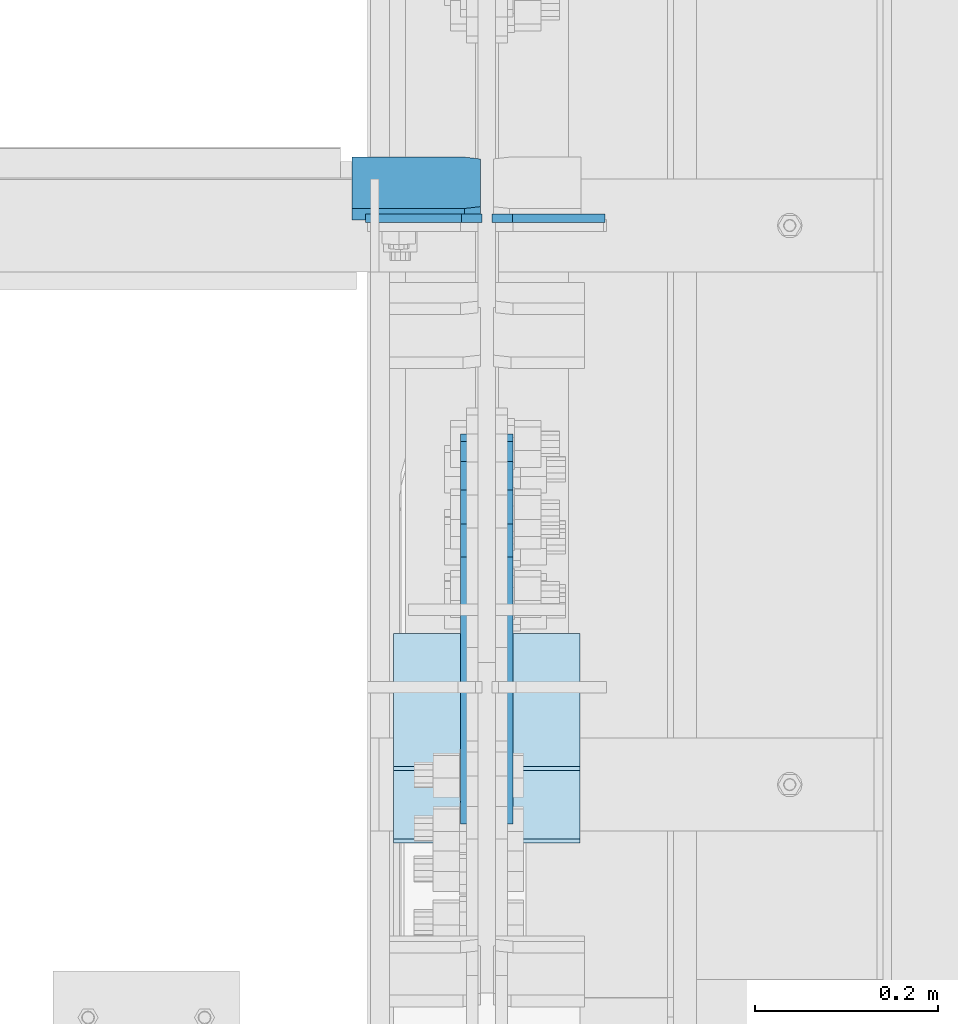
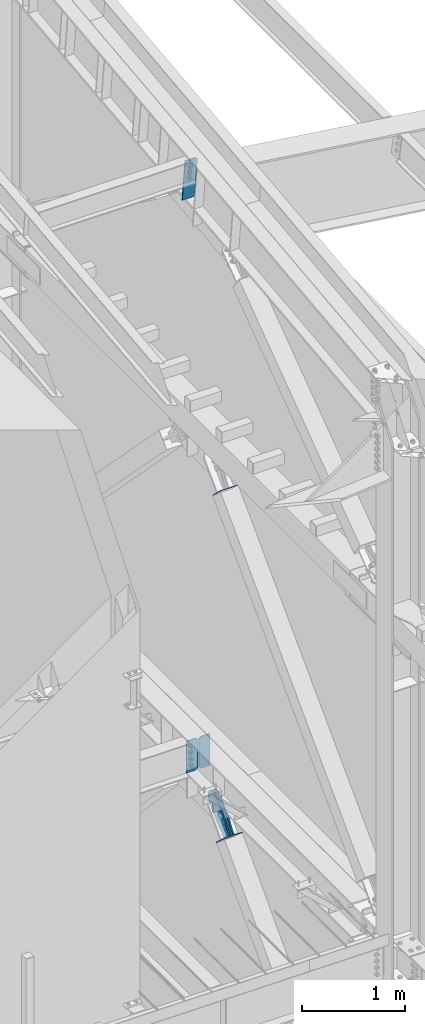
# One storey, part 1013 of 1179: 7 plates, 6 elements without a shape of their own.
"""IFC2X3 building model written with IfcOpenShell, lengths in millimetres."""

from ifc_helpers import new_model, si_unit, frame, origin_with_axes, place, context, subcontext, project, spatial, faceted_brep, material, type_object, element, aggregate, save


model = new_model("IFC2X3")

# Units and contexts
model_context = context("Model", 3, precision=1e-05, world=origin_with_axes())
body_context = subcontext(model_context, "Body", "Model", "MODEL_VIEW")
ifc_project = project(units=[si_unit("LENGTHUNIT", "METRE", prefix="MILLI"), si_unit("AREAUNIT", "SQUARE_METRE"), si_unit("VOLUMEUNIT", "CUBIC_METRE"), si_unit("MASSUNIT", "GRAM", prefix="KILO"), si_unit("TIMEUNIT", "SECOND"), si_unit("PLANEANGLEUNIT", "RADIAN"), si_unit("SOLIDANGLEUNIT", "STERADIAN"), si_unit("THERMODYNAMICTEMPERATUREUNIT", "DEGREE_CELSIUS"), si_unit("LUMINOUSINTENSITYUNIT", "LUMEN")], contexts=[model_context])

# Site, building, storey
site_placement = place(None, origin_with_axes())
site = spatial("IfcSite", under=ifc_project, at=site_placement, CompositionType="ELEMENT")
building_placement = place(site_placement, origin_with_axes())
building = spatial("IfcBuilding", under=site, at=building_placement, Name="Undefined", CompositionType="ELEMENT")
storey_placement = place(building_placement, origin_with_axes())
storey = spatial("IfcBuildingStorey", under=building, at=storey_placement, Name="Undefined", CompositionType="ELEMENT", Elevation=0.0)

# Assembly, plate
assembly_1_placement = place(storey_placement, origin_with_axes())
assembly_1 = element("IfcElementAssembly", 1, at=assembly_1_placement, inside=storey, Name="BEAM", AssemblyPlace="NOTDEFINED", PredefinedType="RIGID_FRAME")
ifc_material_1 = material(Name="STEEL/A572-GR.50")
plate_type_1 = type_object("IfcPlateType", PredefinedType="NOTDEFINED")
plate_1_placement = place(assembly_1_placement, frame((24302.24375, 15362.2375, 3703.6375), z_axis=(0.0, 0.0, 1.0), x_axis=(-1.0, 0.0, 0.0)))
plate_1 = element("IfcPlate", 2, at=plate_1_placement, type_object=plate_type_1, material=ifc_material_1, Name="PLATE", context=body_context, shape_type="Brep", body=[
    faceted_brep([(0.0, -4.76250000000073, 22.2250003814697), (0.0, -4.76249999999709, 355.600011825562), (0.0, 4.76249999999709, 355.600011825562), (0.0, 4.76250000000073, 22.2250003814697), (22.2250003814697, -4.76249999999709, 377.825012207031), (22.2250003814697, 4.76249999999709, 377.825012207031), (127.0, -4.76249999999709, 377.825), (127.0, 4.76249999999709, 377.825), (127.0, -4.76250000000073, 0.0), (127.0, 4.76250000000073, 0.0), (22.2250003814697, -4.76250000000073, 0.0), (22.2250003814697, 4.76250000000073, 0.0)], [[[0, 1, 2, 3]], [[1, 4, 5, 2]], [[4, 6, 7, 5]], [[6, 8, 9, 7]], [[8, 10, 11, 9]], [[10, 0, 3, 11]], [[5, 7, 9, 11, 3, 2]], [[10, 8, 6, 4, 1, 0]]]),
])

assembly_2_placement = place(storey_placement, origin_with_axes())
assembly_2 = element("IfcElementAssembly", 3, at=assembly_2_placement, inside=storey, Name="BEAM", AssemblyPlace="NOTDEFINED", PredefinedType="RIGID_FRAME")
ifc_material_2 = material(Name="STEEL/A36")
plate_type_2 = type_object("IfcPlateType", PredefinedType="NOTDEFINED")
plate_2_placement = place(assembly_2_placement, frame((24300.65625, 15366.6167810572, 10957.7257982143), z_axis=(-1.0, 0.0, 0.0), x_axis=(0.0, 0.112284087038014, -0.993676146336441)))
plate_2 = element("IfcPlate", 4, at=plate_2_placement, type_object=plate_type_2, material=ifc_material_2, Name="PLATE", context=body_context, shape_type="Brep", body=[
    faceted_brep([(0.0, -6.34999999998763, 17.4624996185248), (0.0, -6.34999999999673, 139.700000000001), (-3.63797880709171e-12, 6.34999999999491, 139.700000000001), (0.0, 6.35000000000582, 17.4624996185175), (498.474999999775, -6.34999999979482, 139.700000000001), (498.474999999769, 6.35000000019681, 139.700000000001), (498.474999999775, -6.34999999979482, 17.4624996185303), (498.474999999769, 6.35000000019681, 17.4624996185303), (481.012500381255, -6.34999999980209, 0.0), (481.01250038125, 6.35000000019136, 0.0), (17.4624996185303, -6.34999999999309, 1.81898940354586e-12), (17.4624996185303, 6.34999999999854, -1.81898940354586e-12)], [[[0, 1, 2, 3]], [[1, 4, 5, 2]], [[4, 6, 7, 5]], [[6, 8, 9, 7]], [[8, 10, 11, 9]], [[10, 0, 3, 11]], [[5, 7, 9, 11, 3, 2]], [[10, 8, 6, 4, 1, 0]]]),
])
aggregate(assembly_2, [plate_2])

assembly_3_placement = place(storey_placement, origin_with_axes())
assembly_3 = element("IfcElementAssembly", 5, at=assembly_3_placement, inside=storey, Name="Plate", AssemblyPlace="NOTDEFINED", PredefinedType="RIGID_FRAME")
plate_type_3 = type_object("IfcPlateType", PredefinedType="NOTDEFINED")
plate_3_placement = place(assembly_3_placement, frame((24409.4, 14907.4647442133, 7258.01555767328), z_axis=(0.0, -0.715642339037758, 0.698466923036852), x_axis=(-1.0, 0.0, 0.0)))
plate_3 = element("IfcPlate", 6, at=plate_3_placement, type_object=plate_type_3, material=ifc_material_2, Name="Plate", context=body_context, shape_type="Brep", body=[
    faceted_brep([(0.0, -3.17500000000109, 0.0), (0.0, -3.17500000000291, 203.200000000368), (0.0, 3.17499999998836, 203.200000000361), (0.0, 3.17500000000109, 7.27595761418343e-12), (203.199999999997, -3.17500000000291, 203.200000000368), (203.199999999997, 3.17499999998836, 203.200000000361), (203.199999999997, -3.17499999999927, 3.63797880709171e-12), (203.199999999997, 3.17499999999382, -3.63797880709171e-12)], [[[0, 1, 2, 3]], [[1, 4, 5, 2]], [[4, 6, 7, 5]], [[6, 0, 3, 7]], [[5, 7, 3, 2]], [[6, 4, 1, 0]]]),
])
aggregate(assembly_3, [plate_3])

assembly_4_placement = place(storey_placement, origin_with_axes())
assembly_4 = element("IfcElementAssembly", 7, at=assembly_4_placement, inside=storey, Name="Plate", AssemblyPlace="NOTDEFINED", PredefinedType="RIGID_FRAME")
plate_4_placement = place(assembly_4_placement, frame((24409.4, 14831.2224671031, 3189.63896364117), z_axis=(0.0, -0.727605443744034, 0.685995858758671), x_axis=(-1.0, 0.0, 0.0)))
plate_4 = element("IfcPlate", 8, at=plate_4_placement, type_object=plate_type_3, material=ifc_material_2, Name="Plate", context=body_context, shape_type="Brep", body=[
    faceted_brep([(0.0, -3.17500000000109, 0.0), (0.0, -3.17500000000291, 203.200000000368), (0.0, 3.17499999998836, 203.200000000361), (0.0, 3.17500000000109, 7.27595761418343e-12), (203.199999999997, -3.17500000000291, 203.200000000368), (203.199999999997, 3.17499999998836, 203.200000000361), (203.199999999997, -3.17499999999927, 3.63797880709171e-12), (203.199999999997, 3.17499999999382, -3.63797880709171e-12)], [[[0, 1, 2, 3]], [[1, 4, 5, 2]], [[4, 6, 7, 5]], [[6, 0, 3, 7]], [[5, 7, 3, 2]], [[6, 4, 1, 0]]]),
])
aggregate(assembly_4, [plate_4])

assembly_5_placement = place(storey_placement, origin_with_axes())
assembly_5 = element("IfcElementAssembly", 9, at=assembly_5_placement, inside=storey, AssemblyPlace="NOTDEFINED", PredefinedType="RIGID_FRAME")
plate_type_4 = type_object("IfcPlateType", PredefinedType="NOTDEFINED")
plate_5_placement = place(assembly_5_placement, frame((24287.1625, 14808.5640979315, 3206.63793956581), z_axis=(0.0, -0.727605443744034, 0.685995858758671), x_axis=(0.0, 0.685995858758672, 0.727605443744034)))
plate_5 = element("IfcPlate", 10, at=plate_5_placement, type_object=plate_type_4, material=ifc_material_2, context=body_context, shape_type="Brep", body=[
    faceted_brep([(0.0, -7.9375, 0.0), (-8.00355337560177e-11, -7.9375, 146.904840309817), (-8.00355337560177e-11, 7.9375, 146.904840309817), (0.0, 7.9375, 0.0), (82.5499999998137, -7.9375, 146.90484031055), (82.5499999998137, 7.9375, 146.90484031055), (184.150000000214, -7.9375, 168.702420155054), (184.150000000214, 7.9375, 168.702420155054), (403.471138850085, -7.9375, 168.70242015493), (403.471138850085, 7.9375, 168.70242015493), (439.921735782846, -7.9375, 161.451945626626), (439.921735782846, 7.9375, 161.451945626626), (470.823059758064, -7.9375, 140.804341062974), (470.823059758064, 7.9375, 140.804341062974), (491.470664321725, -7.9375, 109.903017087783), (491.470664321725, 7.9375, 109.903017087783), (498.721138850011, -7.9375, 73.4524201549993), (498.721138850011, 7.9375, 73.4524201549993), (491.470664321694, -7.9375, 37.001823222241), (491.470664321694, 7.9375, 37.001823222241), (470.82305975797, -7.9375, 6.10049924700979), (470.82305975797, 7.9375, 6.10049924700979), (439.921735782676, -7.9375, -14.5471053166548), (439.921735782676, 7.9375, -14.5471053166548), (403.471138849898, -7.9375, -21.7975798449352), (403.471138849898, 7.9375, -21.7975798449352), (184.150000000169, -7.9375, -21.7975798448115), (184.150000000169, 7.9375, -21.7975798448115), (82.5500000000975, -7.9375, -6.91215973347425e-11), (82.5500000000975, 7.9375, -6.91215973347425e-11)], [[[0, 1, 2, 3]], [[1, 4, 5, 2]], [[4, 6, 7, 5]], [[6, 8, 9, 7]], [[8, 10, 11, 9]], [[10, 12, 13, 11]], [[12, 14, 15, 13]], [[14, 16, 17, 15]], [[16, 18, 19, 17]], [[18, 20, 21, 19]], [[20, 22, 23, 21]], [[22, 24, 25, 23]], [[24, 26, 27, 25]], [[26, 28, 29, 27]], [[28, 0, 3, 29]], [[5, 7, 9, 11, 13, 15, 17, 19, 21, 23, 25, 27, 29, 3, 2]], [[28, 26, 24, 22, 20, 18, 16, 14, 12, 10, 8, 6, 4, 1, 0]]]),
])
aggregate(assembly_5, [plate_5])

assembly_6_placement = place(storey_placement, origin_with_axes())
assembly_6 = element("IfcElementAssembly", 11, at=assembly_6_placement, inside=storey, AssemblyPlace="NOTDEFINED", PredefinedType="RIGID_FRAME")
plate_6_placement = place(assembly_6_placement, frame((24328.4375, 14808.5640979315, 3206.63793956581), z_axis=(0.0, -0.727605443744034, 0.685995858758671), x_axis=(0.0, 0.685995858758672, 0.727605443744034)))
plate_6 = element("IfcPlate", 12, at=plate_6_placement, type_object=plate_type_4, material=ifc_material_2, context=body_context, shape_type="Brep", body=[
    faceted_brep([(0.0, -7.9375, 0.0), (-8.00355337560177e-11, -7.9375, 146.904840309817), (-8.00355337560177e-11, 7.9375, 146.904840309817), (0.0, 7.9375, 0.0), (82.5499999998137, -7.9375, 146.90484031055), (82.5499999998137, 7.9375, 146.90484031055), (184.150000000214, -7.9375, 168.702420155054), (184.150000000214, 7.9375, 168.702420155054), (403.471138850085, -7.9375, 168.70242015493), (403.471138850085, 7.9375, 168.70242015493), (439.921735782846, -7.9375, 161.451945626626), (439.921735782846, 7.9375, 161.451945626626), (470.823059758064, -7.9375, 140.804341062974), (470.823059758064, 7.9375, 140.804341062974), (491.470664321725, -7.9375, 109.903017087783), (491.470664321725, 7.9375, 109.903017087783), (498.721138850011, -7.9375, 73.4524201549993), (498.721138850011, 7.9375, 73.4524201549993), (491.470664321694, -7.9375, 37.001823222241), (491.470664321694, 7.9375, 37.001823222241), (470.82305975797, -7.9375, 6.10049924700979), (470.82305975797, 7.9375, 6.10049924700979), (439.921735782676, -7.9375, -14.5471053166548), (439.921735782676, 7.9375, -14.5471053166548), (403.471138849898, -7.9375, -21.7975798449352), (403.471138849898, 7.9375, -21.7975798449352), (184.150000000169, -7.9375, -21.7975798448115), (184.150000000169, 7.9375, -21.7975798448115), (82.5500000000975, -7.9375, -6.91215973347425e-11), (82.5500000000975, 7.9375, -6.91215973347425e-11)], [[[0, 1, 2, 3]], [[1, 4, 5, 2]], [[4, 6, 7, 5]], [[6, 8, 9, 7]], [[8, 10, 11, 9]], [[10, 12, 13, 11]], [[12, 14, 15, 13]], [[14, 16, 17, 15]], [[16, 18, 19, 17]], [[18, 20, 21, 19]], [[20, 22, 23, 21]], [[22, 24, 25, 23]], [[24, 26, 27, 25]], [[26, 28, 29, 27]], [[28, 0, 3, 29]], [[5, 7, 9, 11, 13, 15, 17, 19, 21, 23, 25, 27, 29, 3, 2]], [[28, 26, 24, 22, 20, 18, 16, 14, 12, 10, 8, 6, 4, 1, 0]]]),
])
aggregate(assembly_6, [plate_6])

# Plate
plate_type_5 = type_object("IfcPlateType", PredefinedType="NOTDEFINED")
plate_7_placement = place(assembly_1_placement, frame((24313.35625, 15362.2375, 3703.6375), z_axis=(0.0, 0.0, 1.0), x_axis=(1.0, 0.0, 0.0)))
plate_7 = element("IfcPlate", 13, at=plate_7_placement, type_object=plate_type_5, material=ifc_material_1, Name="PLATE", context=body_context, shape_type="Brep", body=[
    faceted_brep([(0.0, -4.76250000000073, 22.2250003814697), (0.0, -4.76249999999709, 355.600011825562), (0.0, 4.76249999999709, 355.600011825562), (0.0, 4.76250000000073, 22.2250003814697), (22.2250003814697, -4.76249999999709, 377.825012207031), (22.2250003814697, 4.76249999999709, 377.825012207031), (123.03125, -4.76250000000073, 377.825012207031), (123.03125, 4.76250000000073, 377.825012207031), (123.03125, -4.76250000000073, 0.0), (123.03125, 4.76250000000073, 0.0), (22.2250003814697, -4.76250000000073, 0.0), (22.2250003814697, 4.76250000000073, 0.0)], [[[0, 1, 2, 3]], [[1, 4, 5, 2]], [[4, 6, 7, 5]], [[6, 8, 9, 7]], [[8, 10, 11, 9]], [[10, 0, 3, 11]], [[5, 7, 9, 11, 3, 2]], [[10, 8, 6, 4, 1, 0]]]),
])

aggregate(assembly_1, [plate_7, plate_1])

save(model, "model.ifc")
